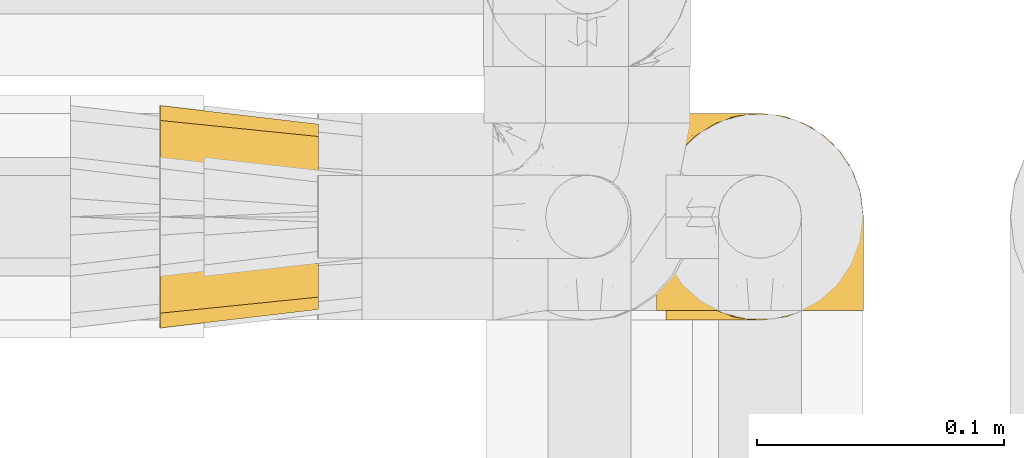
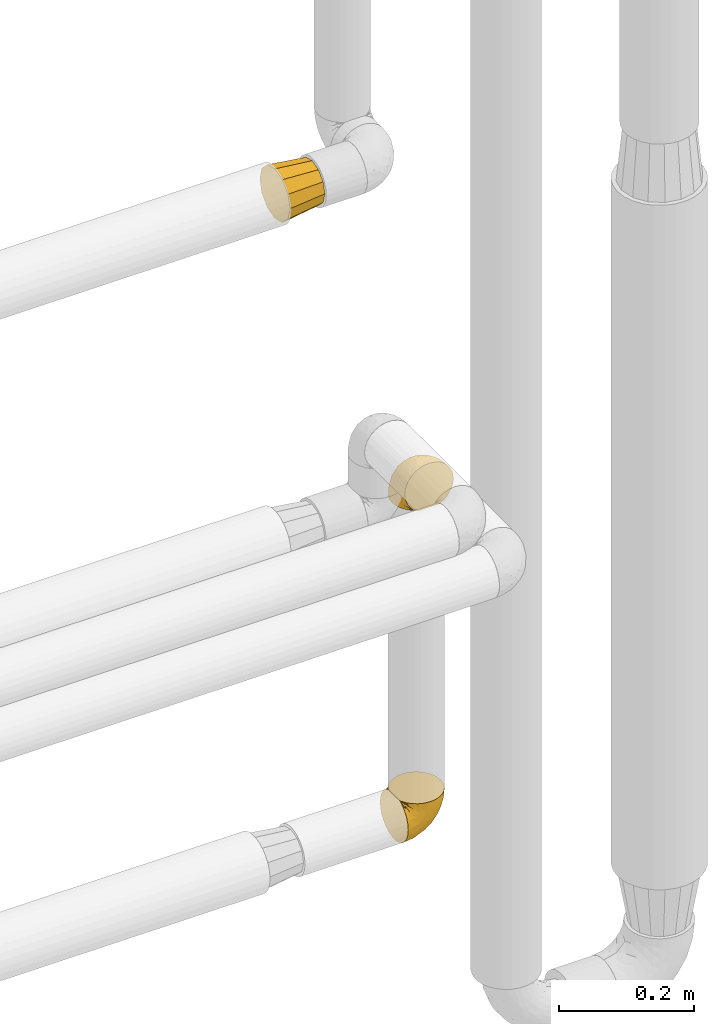
# One storey, part 457 of 827: 3 coverings.
"""IFC2X3 building model written with IfcOpenShell, lengths in millimetres."""

from ifc_helpers import new_model, entity, si_unit, converted_unit, derived_unit, direction, frame, origin, place, context, subcontext, project, spatial, faceted_brep, element, save


model = new_model("IFC2X3")

# Units and contexts
model_context = context("Model", 3, precision=0.01, world=origin(), true_north=direction((6.12303176911189e-17, 1.0)))
body_context = subcontext(model_context, "Body", "Model", "MODEL_VIEW")
ifc_project = project(units=[si_unit("LENGTHUNIT", "METRE", prefix="MILLI"), si_unit("AREAUNIT", "SQUARE_METRE"), si_unit("VOLUMEUNIT", "CUBIC_METRE"), converted_unit("PLANEANGLEUNIT", "DEGREE", entity("IfcRatioMeasure", 0.0174532925199433), si_unit("PLANEANGLEUNIT", "RADIAN"), dimensions=[0, 0, 0, 0, 0, 0, 0]), si_unit("MASSUNIT", "GRAM", prefix="KILO"), derived_unit("MASSDENSITYUNIT", [(si_unit("MASSUNIT", "GRAM", prefix="KILO"), 1), (si_unit("LENGTHUNIT", "METRE"), -3)]), derived_unit("MOMENTOFINERTIAUNIT", [(si_unit("LENGTHUNIT", "METRE"), 4)]), si_unit("TIMEUNIT", "SECOND"), si_unit("FREQUENCYUNIT", "HERTZ"), si_unit("THERMODYNAMICTEMPERATUREUNIT", "DEGREE_CELSIUS"), derived_unit("THERMALTRANSMITTANCEUNIT", [(si_unit("MASSUNIT", "GRAM", prefix="KILO"), 1), (si_unit("THERMODYNAMICTEMPERATUREUNIT", "KELVIN"), -1), (si_unit("TIMEUNIT", "SECOND"), -3)]), derived_unit("VOLUMETRICFLOWRATEUNIT", [(si_unit("LENGTHUNIT", "METRE"), 3), (si_unit("TIMEUNIT", "SECOND"), -1)]), derived_unit("MASSFLOWRATEUNIT", [(si_unit("MASSUNIT", "GRAM", prefix="KILO"), 1), (si_unit("TIMEUNIT", "SECOND"), -1)]), derived_unit("ROTATIONALFREQUENCYUNIT", [(si_unit("TIMEUNIT", "SECOND"), -1)]), si_unit("ELECTRICCURRENTUNIT", "AMPERE"), si_unit("ELECTRICVOLTAGEUNIT", "VOLT"), si_unit("POWERUNIT", "WATT"), si_unit("FORCEUNIT", "NEWTON", prefix="KILO"), si_unit("ILLUMINANCEUNIT", "LUX"), si_unit("LUMINOUSFLUXUNIT", "LUMEN"), si_unit("LUMINOUSINTENSITYUNIT", "CANDELA"), derived_unit("USERDEFINED", [(si_unit("MASSUNIT", "GRAM", prefix="KILO"), -1), (si_unit("LENGTHUNIT", "METRE"), -2), (si_unit("TIMEUNIT", "SECOND"), 3), (si_unit("LUMINOUSFLUXUNIT", "LUMEN"), 1)]), derived_unit("LINEARVELOCITYUNIT", [(si_unit("LENGTHUNIT", "METRE"), 1), (si_unit("TIMEUNIT", "SECOND"), -1)]), si_unit("PRESSUREUNIT", "PASCAL"), derived_unit("USERDEFINED", [(si_unit("LENGTHUNIT", "METRE"), -2), (si_unit("MASSUNIT", "GRAM", prefix="KILO"), 1), (si_unit("TIMEUNIT", "SECOND"), -2)]), derived_unit("LINEARFORCEUNIT", [(si_unit("MASSUNIT", "GRAM", prefix="KILO"), 1), (si_unit("LENGTHUNIT", "METRE"), 1), (si_unit("TIMEUNIT", "SECOND"), -2), (si_unit("LENGTHUNIT", "METRE"), -1)]), derived_unit("PLANARFORCEUNIT", [(si_unit("MASSUNIT", "GRAM", prefix="KILO"), 1), (si_unit("LENGTHUNIT", "METRE"), 1), (si_unit("TIMEUNIT", "SECOND"), -2), (si_unit("LENGTHUNIT", "METRE"), -2)])], contexts=[model_context])

# Site, building, storey
site_placement = place(None, origin())
site = spatial("IfcSite", under=ifc_project, at=site_placement, CompositionType="ELEMENT")
building_placement = place(site_placement, origin())
building = spatial("IfcBuilding", under=site, at=building_placement, CompositionType="ELEMENT")
storey_placement = place(building_placement, frame((0.0, 0.0, 28200.0)))
storey = spatial("IfcBuildingStorey", under=building, at=storey_placement, Name="08", CompositionType="ELEMENT", Elevation=28200.0)

# Coverings
covering_1_placement = place(storey_placement, frame((56390.69, 17453.4, 1945.9)))
element("IfcCovering", 1, at=covering_1_placement, inside=storey, Name=":ADSK_", ObjectType=":ADSK_", PredefinedType="INSULATION", context=body_context, shape_type="Brep", body=[
    faceted_brep([(64.0, 9.1, 46.6), (64.0, 11.61, 37.22), (64.0, 14.12, 27.85), (64.0, 20.98, 20.98), (64.0, 27.85, 14.12), (64.0, 37.22, 11.61), (64.0, 46.6, 9.1), (64.0, 55.97, 11.61), (64.0, 65.35, 14.12), (64.0, 72.21, 20.98), (64.0, 79.07, 27.85), (64.0, 81.58, 37.22), (64.0, 84.1, 46.6), (64.0, 81.58, 55.97), (64.0, 79.07, 65.35), (64.0, 72.21, 72.21), (64.0, 65.35, 79.07), (64.0, 55.97, 81.58), (64.0, 46.6, 84.1), (64.0, 37.22, 81.58), (64.0, 27.85, 79.07), (64.0, 20.98, 72.21), (64.0, 14.12, 65.35), (64.0, 11.61, 55.97), (0.0, 77.33, 77.33), (0.0, 85.57, 69.1), (0.0, 88.1, 59.65), (0.0, 91.6, 46.6), (0.0, 88.1, 33.54), (0.0, 85.57, 24.1), (0.0, 77.33, 15.86), (0.0, 69.1, 7.62), (0.0, 59.65, 5.09), (0.0, 46.6, 1.6), (0.0, 33.54, 5.09), (0.0, 24.1, 7.62), (0.0, 15.86, 15.86), (0.0, 7.62, 24.1), (0.0, 5.09, 33.54), (0.0, 1.6, 46.6), (0.0, 5.09, 59.65), (0.0, 7.62, 69.1), (0.0, 15.86, 77.33), (0.0, 24.1, 85.57), (0.0, 33.54, 88.1), (0.0, 46.6, 91.6), (0.0, 59.65, 88.1), (0.0, 69.1, 85.57)], [[[0, 1, 2, 3, 4, 5, 6, 7, 8, 9, 10, 11, 12, 13, 14, 15, 16, 17, 18, 19, 20, 21, 22, 23]], [[24, 25, 26, 27, 28, 29, 30, 31, 32, 33, 34, 35, 36, 37, 38, 39, 40, 41, 42, 43, 44, 45, 46, 47]], [[4, 35, 34, 33, 6, 5]], [[37, 36, 35, 4, 3, 2]], [[1, 0, 39, 38, 37, 2]], [[10, 29, 28, 27, 12, 11]], [[31, 30, 29, 10, 9, 8]], [[7, 6, 33, 32, 31, 8]], [[16, 47, 46, 45, 18, 17]], [[25, 24, 47, 16, 15, 14]], [[13, 12, 27, 26, 25, 14]], [[22, 41, 40, 39, 0, 23]], [[43, 42, 41, 22, 21, 20]], [[19, 18, 45, 44, 43, 20]]]),
])
covering_2_placement = place(storey_placement, frame((56589.78, 17460.4, 1360.4)))
element("IfcCovering", 2, at=covering_2_placement, inside=storey, Name=":ADSK_", ObjectType=":ADSK_", PredefinedType="INSULATION", context=body_context, shape_type="Brep", body=[
    faceted_brep([(5.74, 57.76, 1.6), (10.73, 65.69, 1.6), (17.36, 72.32, 1.6), (25.29, 77.3, 1.6), (34.14, 80.4, 1.6), (43.45, 81.45, 1.6), (52.76, 80.39, 1.6), (61.61, 77.3, 1.6), (69.54, 72.31, 1.6), (76.17, 65.68, 1.6), (81.15, 57.75, 1.6), (84.25, 48.9, 1.6), (85.3, 39.6, 1.6), (84.23, 30.22, 1.6), (81.1, 21.33, 1.6), (76.06, 13.37, 1.6), (69.36, 6.73, 1.6), (61.36, 1.77, 1.6), (60.44, 1.77, 1.6), (59.52, 1.77, 1.6), (58.72, 1.77, 1.6), (57.4, 1.77, 1.6), (56.08, 1.77, 1.6), (54.76, 1.77, 1.6), (53.44, 1.77, 1.6), (52.12, 1.77, 1.6), (50.8, 1.77, 1.6), (49.47, 1.77, 1.6), (48.15, 1.77, 1.6), (46.83, 1.77, 1.6), (45.51, 1.77, 1.6), (44.19, 1.77, 1.6), (42.87, 1.77, 1.6), (41.55, 1.77, 1.6), (40.23, 1.77, 1.6), (39.31, 1.77, 1.6), (38.39, 1.77, 1.6), (37.48, 1.77, 1.6), (36.56, 1.77, 1.6), (35.64, 1.77, 1.6), (34.72, 1.77, 1.6), (33.8, 1.77, 1.6), (32.88, 1.77, 1.6), (31.96, 1.77, 1.6), (31.05, 1.77, 1.6), (30.13, 1.77, 1.6), (29.21, 1.77, 1.6), (28.29, 1.77, 1.6), (27.37, 1.77, 1.6), (26.45, 1.77, 1.6), (25.53, 1.77, 1.6), (17.52, 6.74, 1.6), (10.82, 13.38, 1.6), (5.78, 21.35, 1.6), (2.65, 30.24, 1.6), (1.6, 39.6, 1.6), (2.65, 48.91, 1.6), (69.37, 1.6, 6.74), (76.06, 1.6, 13.37), (81.1, 1.6, 21.34), (84.23, 1.6, 30.23), (85.3, 1.6, 39.6), (83.87, 1.6, 50.43), (79.69, 1.6, 60.52), (73.04, 1.6, 69.19), (64.37, 1.6, 75.84), (54.28, 1.6, 80.02), (43.45, 1.6, 81.45), (32.61, 1.6, 80.02), (22.52, 1.6, 75.84), (13.85, 1.6, 69.19), (7.2, 1.6, 60.52), (3.02, 1.6, 50.43), (1.6, 1.6, 39.6), (2.66, 1.6, 30.23), (5.79, 1.6, 21.34), (10.83, 1.6, 13.37), (17.52, 1.6, 6.74), (25.53, 1.6, 1.77), (26.45, 1.6, 1.77), (27.77, 1.6, 1.77), (28.89, 1.6, 1.77), (30.01, 1.6, 1.77), (31.13, 1.6, 1.77), (32.25, 1.6, 1.77), (33.37, 1.6, 1.77), (34.49, 1.6, 1.77), (35.61, 1.6, 1.77), (36.73, 1.6, 1.77), (37.85, 1.6, 1.77), (38.97, 1.6, 1.77), (40.09, 1.6, 1.77), (41.21, 1.6, 1.77), (42.33, 1.6, 1.77), (43.45, 1.6, 1.77), (44.77, 1.6, 1.77), (46.09, 1.6, 1.77), (47.41, 1.6, 1.77), (48.73, 1.6, 1.77), (50.05, 1.6, 1.77), (51.37, 1.6, 1.77), (52.69, 1.6, 1.77), (54.01, 1.6, 1.77), (54.93, 1.6, 1.77), (55.85, 1.6, 1.77), (56.76, 1.6, 1.77), (57.68, 1.6, 1.77), (58.6, 1.6, 1.77), (59.52, 1.6, 1.77), (60.44, 1.6, 1.77), (61.36, 1.6, 1.77), (32.81, 1.71, 1.73), (31.73, 1.73, 1.72), (50.71, 1.71, 1.73), (51.76, 1.72, 1.72), (42.89, 1.71, 1.73), (41.81, 1.72, 1.73), (25.53, 1.72, 1.72), (26.91, 1.72, 1.72), (40.71, 1.72, 1.72), (60.15, 1.72, 1.72), (39.53, 1.72, 1.72), (57.22, 1.72, 1.73), (58.17, 1.7, 1.74), (47.12, 1.72, 1.72), (33.93, 1.73, 1.71), (35.05, 1.72, 1.73), (46.09, 1.73, 1.71), (45.02, 1.73, 1.72), (43.95, 1.72, 1.73), (59.12, 1.72, 1.72), (38.49, 1.71, 1.73), (49.68, 1.72, 1.72), (53.35, 1.71, 1.73), (54.4, 1.72, 1.72), (56.2, 1.72, 1.72), (36.2, 1.72, 1.72), (37.29, 1.73, 1.71), (30.57, 1.72, 1.72), (29.45, 1.71, 1.73), (28.01, 1.73, 1.71), (61.36, 1.72, 1.72), (25.53, 1.74, 1.68), (25.53, 1.75, 1.64), (61.36, 1.75, 1.64), (61.36, 1.74, 1.68), (25.53, 1.64, 1.75), (25.53, 1.68, 1.74), (61.36, 1.68, 1.74), (61.36, 1.64, 1.75), (55.3, 1.74, 1.7), (48.18, 1.71, 1.73), (82.92, 8.98, 24.54), (85.3, 37.05, 11.1), (82.92, 24.69, 8.47), (78.8, 15.28, 9.11), (78.8, 16.86, 4.86), (70.46, 6.58, 5.0), (71.16, 5.71, 6.81), (85.3, 11.1, 37.05), (76.1, 10.79, 9.03), (72.9, 4.13, 9.47), (78.81, 6.62, 16.39), (72.89, 9.52, 3.95), (74.06, 6.14, 9.9), (83.71, 17.79, 22.7), (85.3, 20.6, 34.5), (85.3, 8.73, 37.68), (83.61, 23.66, 15.82), (85.3, 34.5, 20.6), (80.61, 15.32, 14.37), (85.3, 27.55, 27.55), (67.83, 3.31, 5.2), (78.81, 9.81, 14.88), (85.3, 37.68, 8.73), (54.78, 67.23, 44.27), (57.27, 76.64, 20.94), (43.45, 75.37, 32.15), (84.45, 14.58, 46.13), (84.39, 23.71, 42.67), (77.16, 34.34, 55.18), (68.92, 29.1, 67.27), (76.65, 18.02, 62.91), (82.11, 22.27, 51.5), (82.11, 10.97, 54.79), (78.88, 56.79, 25.78), (78.88, 60.76, 13.05), (73.04, 67.04, 18.46), (84.47, 36.11, 32.4), (65.72, 68.85, 31.07), (51.16, 24.58, 77.32), (59.46, 21.54, 75.62), (43.45, 78.4, 16.9), (68.92, 14.11, 71.69), (51.18, 53.42, 61.4), (57.42, 58.19, 54.47), (83.48, 44.49, 27.66), (82.95, 51.77, 14.53), (65.72, 73.69, 15.56), (78.97, 45.89, 42.26), (82.64, 35.97, 41.51), (75.14, 56.55, 36.93), (68.58, 60.03, 42.72), (61.95, 63.64, 44.68), (58.11, 34.98, 71.2), (51.07, 40.58, 70.48), (43.45, 32.15, 75.37), (58.51, 47.26, 63.65), (43.45, 58.06, 58.06), (43.45, 66.71, 45.11), (43.45, 16.9, 78.4), (65.68, 52.08, 54.95), (70.41, 41.21, 59.31), (73.04, 49.76, 49.01), (43.45, 45.11, 66.71), (4.78, 15.65, 53.75), (35.48, 24.57, 77.27), (29.45, 50.54, 61.6), (32.11, 67.25, 44.24), (13.86, 67.06, 18.46), (21.19, 73.7, 15.55), (10.24, 26.13, 60.14), (17.97, 19.54, 70.5), (18.88, 38.96, 63.0), (8.01, 56.8, 25.78), (8.01, 60.77, 13.05), (3.95, 51.78, 14.53), (22.45, 59.09, 48.5), (2.4, 19.25, 44.23), (1.6, 20.6, 34.5), (1.6, 11.1, 37.05), (1.6, 37.68, 8.73), (29.05, 15.21, 77.68), (10.24, 12.76, 64.08), (35.7, 40.93, 70.25), (29.63, 76.65, 20.93), (8.75, 39.5, 49.9), (4.54, 25.01, 49.6), (21.19, 68.86, 31.06), (2.28, 26.7, 39.62), (2.53, 34.95, 34.42), (1.6, 34.5, 20.6), (1.6, 27.55, 27.55), (13.86, 61.27, 33.36), (3.41, 44.5, 27.68), (1.6, 37.05, 11.1), (2.35, 10.25, 46.67), (13.86, 49.78, 49.0), (7.35, 47.51, 38.94), (27.43, 29.38, 73.05), (13.39, 40.01, 56.63), (4.32, 33.36, 43.85), (3.97, 8.98, 24.54), (3.27, 23.67, 15.82), (3.97, 24.71, 8.47), (8.08, 15.29, 9.12), (13.99, 4.13, 9.47), (12.83, 6.14, 9.91), (8.08, 4.96, 16.85), (8.08, 9.81, 14.88), (19.06, 3.31, 5.2), (15.74, 5.7, 6.81), (13.98, 9.53, 3.96), (16.42, 6.59, 5.0), (8.08, 16.63, 5.86), (6.27, 15.34, 14.38), (10.78, 10.8, 9.04), (3.18, 17.79, 22.7)], [[[0, 1, 2, 3, 4, 5, 6, 7, 8, 9, 10, 11, 12, 13, 14, 15, 16, 17, 18, 19, 20, 21, 22, 23, 24, 25, 26, 27, 28, 29, 30, 31, 32, 33, 34, 35, 36, 37, 38, 39, 40, 41, 42, 43, 44, 45, 46, 47, 48, 49, 50, 51, 52, 53, 54, 55, 56]], [[57, 58, 59, 60, 61, 62, 63, 64, 65, 66, 67, 68, 69, 70, 71, 72, 73, 74, 75, 76, 77, 78, 79, 80, 81, 82, 83, 84, 85, 86, 87, 88, 89, 90, 91, 92, 93, 94, 95, 96, 97, 98, 99, 100, 101, 102, 103, 104, 105, 106, 107, 108, 109, 110]], [[111, 84, 112]], [[113, 26, 114]], [[114, 101, 100]], [[115, 93, 116]], [[79, 117, 118]], [[33, 116, 119]], [[117, 49, 118]], [[19, 18, 120]], [[119, 121, 34]], [[122, 21, 123]], [[97, 96, 124]], [[86, 125, 126]], [[116, 92, 119]], [[127, 96, 128]], [[32, 129, 115]], [[19, 120, 130]], [[121, 90, 131]], [[94, 115, 129]], [[115, 116, 32]], [[118, 49, 48]], [[113, 99, 132]], [[133, 114, 25]], [[24, 134, 133]], [[135, 22, 122]], [[136, 137, 88]], [[84, 83, 112]], [[138, 82, 139]], [[130, 20, 19]], [[118, 48, 140]], [[81, 140, 139]], [[123, 21, 20]], [[141, 120, 18]], [[139, 82, 81]], [[130, 107, 123]], [[49, 117, 142, 143, 50]], [[18, 17, 144, 145, 141]], [[79, 78, 146, 147, 117]], [[109, 141, 148, 149, 110]], [[102, 133, 134]], [[105, 135, 122]], [[118, 80, 79]], [[80, 118, 140]], [[120, 109, 108]], [[47, 46, 140, 48]], [[81, 80, 140]], [[44, 112, 138]], [[93, 115, 94]], [[46, 139, 140]], [[46, 45, 139]], [[139, 45, 138]], [[138, 112, 83]], [[85, 84, 111]], [[112, 43, 111]], [[83, 82, 138]], [[106, 122, 123]], [[105, 122, 106]], [[21, 122, 22]], [[124, 29, 28]], [[33, 32, 116]], [[128, 129, 31]], [[32, 31, 129]], [[34, 33, 119]], [[116, 93, 92]], [[129, 95, 94]], [[95, 129, 128]], [[41, 40, 125, 42]], [[119, 91, 121]], [[36, 35, 131, 37]], [[137, 131, 89]], [[121, 131, 35]], [[90, 121, 91]], [[119, 92, 91]], [[136, 126, 39]], [[125, 86, 85]], [[42, 125, 111]], [[85, 111, 125]], [[150, 23, 22]], [[130, 108, 107]], [[130, 123, 20]], [[107, 106, 123]], [[137, 37, 131]], [[136, 38, 137]], [[89, 88, 137]], [[131, 90, 89]], [[124, 151, 97]], [[40, 39, 126]], [[87, 126, 136]], [[86, 126, 87]], [[136, 88, 87]], [[40, 126, 125]], [[39, 38, 136]], [[95, 128, 96]], [[30, 128, 31]], [[29, 124, 127]], [[127, 128, 30]], [[151, 124, 28]], [[127, 30, 29]], [[127, 124, 96]], [[151, 98, 97]], [[45, 44, 138]], [[26, 113, 132]], [[113, 100, 99]], [[132, 151, 27]], [[27, 26, 132]], [[26, 25, 114]], [[100, 113, 114]], [[101, 133, 102]], [[133, 101, 114]], [[28, 27, 151]], [[132, 99, 98]], [[23, 134, 24]], [[25, 24, 133]], [[134, 23, 150]], [[135, 104, 150]], [[150, 104, 103]], [[103, 102, 134]], [[130, 120, 108]], [[109, 120, 141]], [[42, 111, 43]], [[112, 44, 43]], [[104, 135, 105]], [[134, 150, 103]], [[135, 150, 22]], [[35, 34, 121]], [[137, 38, 37]], [[98, 151, 132]], [[59, 152, 60]], [[13, 153, 154]], [[155, 156, 154]], [[157, 158, 141]], [[159, 60, 152]], [[160, 157, 155]], [[161, 162, 58]], [[58, 162, 59]], [[144, 16, 163]], [[58, 57, 161]], [[162, 161, 164]], [[157, 163, 155]], [[163, 16, 15]], [[57, 149, 161]], [[152, 165, 166]], [[157, 144, 163]], [[60, 159, 167, 61]], [[156, 14, 154]], [[163, 156, 155]], [[155, 154, 168]], [[168, 154, 169]], [[155, 170, 160]], [[57, 110, 149]], [[144, 17, 16]], [[156, 15, 14]], [[171, 165, 168]], [[158, 164, 172]], [[14, 13, 154]], [[157, 141, 145, 144]], [[173, 164, 158]], [[173, 160, 170]], [[171, 166, 165]], [[168, 165, 170]], [[168, 169, 171]], [[152, 173, 165]], [[170, 155, 168]], [[165, 173, 170]], [[160, 173, 158]], [[172, 149, 148]], [[148, 141, 158]], [[158, 157, 160]], [[152, 166, 159]], [[173, 152, 162]], [[59, 162, 152]], [[13, 12, 174, 153]], [[153, 169, 154]], [[15, 156, 163]], [[162, 164, 173]], [[172, 164, 161]], [[149, 172, 161]], [[158, 172, 148]], [[175, 176, 177]], [[178, 166, 179]], [[180, 181, 182]], [[183, 184, 178]], [[185, 186, 187]], [[171, 188, 179]], [[174, 12, 11]], [[189, 176, 175]], [[190, 66, 191]], [[176, 6, 192]], [[193, 65, 64]], [[63, 184, 182]], [[63, 182, 64]], [[65, 193, 191]], [[184, 63, 62]], [[175, 194, 195]], [[196, 169, 197]], [[174, 11, 197]], [[8, 7, 198]], [[187, 9, 8]], [[197, 169, 153, 174]], [[197, 11, 10]], [[186, 197, 10]], [[199, 180, 200]], [[197, 185, 196]], [[201, 189, 202]], [[201, 187, 189]], [[195, 203, 175]], [[191, 204, 190]], [[176, 7, 6]], [[177, 176, 192]], [[189, 198, 176]], [[65, 191, 66]], [[198, 187, 8]], [[205, 206, 190]], [[9, 186, 10]], [[181, 207, 204]], [[208, 175, 177, 209]], [[66, 190, 210]], [[211, 212, 213]], [[190, 204, 205]], [[180, 182, 183]], [[193, 182, 181]], [[62, 61, 167]], [[196, 185, 199]], [[196, 200, 188]], [[6, 5, 192]], [[176, 198, 7]], [[187, 198, 189]], [[187, 186, 9]], [[197, 186, 185]], [[200, 180, 183]], [[180, 213, 212]], [[179, 183, 178]], [[185, 201, 199]], [[210, 190, 206]], [[210, 67, 66]], [[205, 204, 207]], [[194, 205, 207]], [[194, 214, 205]], [[195, 194, 207]], [[208, 194, 175]], [[207, 211, 195]], [[202, 203, 211]], [[212, 207, 181]], [[202, 211, 213]], [[201, 202, 213]], [[189, 175, 203]], [[199, 201, 213]], [[187, 201, 185]], [[180, 199, 213]], [[196, 199, 200]], [[211, 203, 195]], [[189, 203, 202]], [[207, 212, 211]], [[180, 212, 181]], [[214, 194, 208]], [[214, 206, 205]], [[196, 188, 169]], [[181, 204, 191]], [[182, 193, 64]], [[191, 193, 181]], [[178, 62, 167]], [[182, 184, 183]], [[62, 178, 184]], [[178, 167, 159, 166]], [[171, 179, 166]], [[200, 183, 179]], [[179, 188, 200]], [[169, 188, 171]], [[71, 215, 72]], [[206, 216, 210]], [[217, 208, 218]], [[216, 68, 210]], [[219, 220, 2]], [[221, 222, 223]], [[224, 225, 226]], [[227, 223, 217]], [[228, 229, 230]], [[56, 231, 226]], [[232, 222, 69]], [[56, 55, 231]], [[70, 233, 71]], [[71, 233, 215]], [[0, 56, 226]], [[208, 217, 234]], [[218, 177, 235]], [[221, 236, 237]], [[238, 220, 219]], [[1, 219, 2]], [[68, 216, 232]], [[235, 3, 220]], [[235, 192, 4]], [[1, 0, 225]], [[228, 239, 229]], [[240, 241, 242]], [[243, 238, 219]], [[224, 226, 244]], [[226, 241, 244]], [[3, 235, 4]], [[69, 222, 70]], [[225, 219, 1]], [[218, 235, 238]], [[243, 219, 224]], [[218, 227, 217]], [[3, 2, 220]], [[218, 208, 209, 177]], [[226, 231, 245, 241]], [[215, 228, 246]], [[247, 248, 236]], [[248, 224, 244]], [[223, 222, 249]], [[233, 222, 221]], [[242, 239, 240]], [[248, 247, 243]], [[217, 223, 249]], [[250, 247, 236]], [[216, 234, 249]], [[218, 238, 227]], [[192, 235, 177]], [[192, 5, 4]], [[72, 246, 73]], [[235, 220, 238]], [[226, 225, 0]], [[219, 225, 224]], [[240, 248, 244]], [[239, 242, 229]], [[236, 248, 251]], [[68, 67, 210]], [[234, 216, 206]], [[216, 249, 232]], [[234, 206, 214, 208]], [[249, 234, 217]], [[222, 232, 249]], [[69, 68, 232]], [[246, 228, 230]], [[237, 228, 215]], [[243, 227, 238]], [[223, 227, 247]], [[73, 246, 230]], [[215, 246, 72]], [[248, 243, 224]], [[227, 243, 247]], [[237, 236, 251]], [[250, 221, 223]], [[222, 233, 70]], [[215, 233, 221]], [[221, 237, 215]], [[239, 237, 251]], [[237, 239, 228]], [[239, 251, 240]], [[248, 240, 251]], [[241, 240, 244]], [[221, 250, 236]], [[223, 247, 250]], [[74, 230, 252]], [[253, 254, 255]], [[146, 77, 256]], [[257, 258, 259]], [[260, 256, 257]], [[260, 261, 147]], [[75, 74, 252]], [[51, 143, 262]], [[263, 143, 142, 117]], [[256, 77, 76]], [[252, 258, 75]], [[253, 241, 254]], [[254, 245, 54]], [[258, 256, 76]], [[53, 52, 264]], [[255, 265, 253]], [[254, 264, 255]], [[255, 264, 262]], [[75, 258, 76]], [[265, 255, 266]], [[255, 262, 263]], [[51, 50, 143]], [[54, 245, 231, 55]], [[51, 262, 52]], [[253, 267, 242]], [[254, 54, 53]], [[266, 259, 265]], [[146, 78, 77]], [[263, 117, 261]], [[146, 256, 260]], [[257, 259, 261]], [[267, 253, 265]], [[229, 267, 252]], [[242, 267, 229]], [[242, 241, 253]], [[252, 267, 259]], [[255, 263, 266]], [[259, 267, 265]], [[261, 117, 147]], [[263, 261, 266]], [[259, 266, 261]], [[230, 74, 73]], [[230, 229, 252]], [[259, 258, 252]], [[254, 241, 245]], [[53, 264, 254]], [[52, 262, 264]], [[143, 263, 262]], [[258, 257, 256]], [[261, 260, 257]], [[146, 260, 147]]]),
])
covering_3_placement = place(storey_placement, frame((56593.63, 17456.55, 749.05)))
element("IfcCovering", 3, at=covering_3_placement, inside=storey, Name=":ADSK_", ObjectType=":ADSK_", PredefinedType="INSULATION", context=body_context, shape_type="Brep", body=[
    faceted_brep([(1.6, 81.15, 25.28), (1.6, 76.16, 17.35), (1.6, 69.53, 10.72), (1.6, 61.6, 5.74), (1.6, 52.75, 2.64), (1.6, 43.45, 1.6), (1.6, 34.13, 2.65), (1.6, 25.28, 5.74), (1.6, 17.35, 10.73), (1.6, 10.72, 17.36), (1.6, 5.74, 25.29), (1.6, 2.64, 34.14), (1.6, 1.6, 43.45), (1.6, 2.66, 52.82), (1.6, 5.79, 61.71), (1.6, 10.83, 69.67), (1.6, 17.53, 76.31), (1.6, 25.53, 81.27), (1.6, 26.45, 81.27), (1.6, 27.37, 81.27), (1.6, 28.17, 81.27), (1.6, 29.49, 81.27), (1.6, 30.81, 81.27), (1.6, 32.13, 81.27), (1.6, 33.45, 81.27), (1.6, 34.78, 81.27), (1.6, 36.1, 81.27), (1.6, 37.42, 81.27), (1.6, 38.74, 81.27), (1.6, 40.06, 81.27), (1.6, 41.38, 81.27), (1.6, 42.7, 81.27), (1.6, 44.02, 81.27), (1.6, 45.34, 81.27), (1.6, 46.66, 81.27), (1.6, 47.58, 81.27), (1.6, 48.5, 81.27), (1.6, 49.41, 81.27), (1.6, 50.33, 81.27), (1.6, 51.25, 81.27), (1.6, 52.17, 81.27), (1.6, 53.09, 81.27), (1.6, 54.01, 81.27), (1.6, 54.93, 81.27), (1.6, 55.85, 81.27), (1.6, 56.76, 81.27), (1.6, 57.68, 81.27), (1.6, 58.6, 81.27), (1.6, 59.52, 81.27), (1.6, 60.44, 81.27), (1.6, 61.36, 81.27), (1.6, 69.37, 76.3), (1.6, 76.07, 69.66), (1.6, 81.11, 61.69), (1.6, 84.24, 52.8), (1.6, 85.3, 43.45), (1.6, 84.24, 34.13), (6.74, 17.52, 81.45), (13.37, 10.83, 81.45), (21.34, 5.79, 81.45), (30.23, 2.66, 81.45), (39.6, 1.6, 81.45), (50.43, 3.02, 81.45), (60.52, 7.2, 81.45), (69.19, 13.85, 81.45), (75.84, 22.52, 81.45), (80.02, 32.61, 81.45), (81.45, 43.45, 81.45), (80.02, 54.28, 81.45), (75.84, 64.37, 81.45), (69.19, 73.04, 81.45), (60.52, 79.69, 81.45), (50.43, 83.87, 81.45), (39.6, 85.3, 81.45), (30.23, 84.23, 81.45), (21.34, 81.1, 81.45), (13.37, 76.06, 81.45), (6.74, 69.37, 81.45), (1.77, 61.36, 81.45), (1.77, 60.44, 81.45), (1.77, 59.12, 81.45), (1.77, 58.0, 81.45), (1.77, 56.88, 81.45), (1.77, 55.76, 81.45), (1.77, 54.64, 81.45), (1.77, 53.52, 81.45), (1.77, 52.4, 81.45), (1.77, 51.28, 81.45), (1.77, 50.16, 81.45), (1.77, 49.04, 81.45), (1.77, 47.92, 81.45), (1.77, 46.8, 81.45), (1.77, 45.68, 81.45), (1.77, 44.56, 81.45), (1.77, 43.45, 81.45), (1.77, 42.12, 81.45), (1.77, 40.8, 81.45), (1.77, 39.48, 81.45), (1.77, 38.16, 81.45), (1.77, 36.84, 81.45), (1.77, 35.52, 81.45), (1.77, 34.2, 81.45), (1.77, 32.88, 81.45), (1.77, 31.96, 81.45), (1.77, 31.05, 81.45), (1.77, 30.13, 81.45), (1.77, 29.21, 81.45), (1.77, 28.29, 81.45), (1.77, 27.37, 81.45), (1.77, 26.45, 81.45), (1.77, 25.53, 81.45), (1.73, 54.08, 81.33), (1.72, 55.16, 81.32), (1.73, 36.18, 81.33), (1.72, 35.13, 81.32), (1.73, 44.01, 81.33), (1.73, 45.08, 81.32), (1.72, 61.36, 81.32), (1.72, 59.98, 81.32), (1.72, 46.18, 81.32), (1.72, 26.74, 81.32), (1.72, 47.36, 81.32), (1.73, 29.67, 81.32), (1.74, 28.72, 81.34), (1.72, 39.77, 81.32), (1.71, 52.96, 81.31), (1.73, 51.84, 81.33), (1.71, 40.8, 81.31), (1.72, 41.87, 81.32), (1.73, 42.94, 81.33), (1.72, 27.77, 81.32), (1.73, 48.4, 81.33), (1.72, 37.21, 81.32), (1.73, 33.54, 81.33), (1.72, 32.49, 81.32), (1.72, 30.69, 81.32), (1.72, 50.69, 81.32), (1.71, 49.6, 81.31), (1.72, 56.32, 81.32), (1.73, 57.44, 81.33), (1.71, 58.88, 81.31), (1.72, 25.53, 81.32), (1.68, 61.36, 81.3), (1.64, 25.53, 81.29), (1.68, 25.53, 81.3), (1.75, 61.36, 81.4), (1.74, 61.36, 81.36), (1.74, 25.53, 81.36), (1.75, 25.53, 81.4), (1.64, 61.36, 81.29), (1.7, 31.59, 81.3), (1.73, 38.71, 81.33), (24.54, 3.97, 74.06), (11.1, 1.6, 45.99), (8.47, 3.97, 58.35), (9.11, 8.09, 67.76), (4.86, 8.09, 66.18), (5.0, 16.43, 76.46), (6.81, 15.73, 77.33), (37.05, 1.6, 71.95), (9.03, 10.79, 72.25), (9.47, 13.99, 78.91), (16.39, 8.08, 76.42), (3.95, 14.0, 73.52), (9.9, 12.83, 76.9), (22.7, 3.18, 65.25), (34.5, 1.6, 62.45), (37.68, 1.6, 74.31), (15.82, 3.28, 59.38), (20.6, 1.6, 48.54), (14.37, 6.28, 67.72), (27.55, 1.6, 55.49), (5.2, 19.06, 79.73), (14.88, 8.08, 73.23), (8.73, 1.6, 45.36), (44.27, 32.11, 15.81), (20.94, 29.62, 6.4), (32.15, 43.45, 7.67), (46.13, 2.45, 68.46), (42.67, 2.5, 59.33), (55.18, 9.73, 48.7), (67.27, 17.97, 53.94), (62.91, 10.24, 65.02), (51.5, 4.78, 60.77), (54.79, 4.78, 72.07), (25.78, 8.01, 26.25), (13.05, 8.01, 22.29), (18.46, 13.85, 16.0), (32.4, 2.42, 46.93), (31.07, 21.17, 14.19), (77.32, 35.73, 58.46), (75.62, 27.43, 61.51), (16.9, 43.45, 4.64), (71.69, 17.97, 68.93), (61.4, 35.71, 29.62), (54.47, 29.47, 24.85), (27.66, 3.41, 38.55), (14.53, 3.94, 31.27), (15.56, 21.17, 9.35), (42.26, 7.92, 37.15), (41.51, 4.25, 47.07), (36.93, 11.75, 26.49), (42.72, 18.31, 23.01), (44.68, 24.94, 19.4), (71.2, 28.78, 48.06), (70.48, 35.82, 42.46), (75.37, 43.45, 50.89), (63.65, 28.38, 35.78), (58.06, 43.45, 24.98), (45.11, 43.45, 16.33), (78.4, 43.45, 66.14), (54.95, 21.21, 30.96), (59.31, 16.48, 41.83), (49.01, 13.85, 33.28), (66.71, 43.45, 37.94), (53.75, 82.11, 67.39), (77.27, 51.41, 58.47), (61.6, 57.45, 32.5), (44.24, 54.78, 15.79), (18.46, 73.03, 15.99), (15.55, 65.7, 9.34), (60.14, 76.65, 56.91), (70.5, 68.92, 63.5), (63.0, 68.01, 44.08), (25.78, 78.88, 26.24), (13.05, 78.88, 22.27), (14.53, 82.94, 31.26), (48.5, 64.44, 23.95), (44.23, 84.49, 63.79), (34.5, 85.3, 62.45), (37.05, 85.3, 71.95), (8.73, 85.3, 45.36), (77.68, 57.84, 67.83), (64.08, 76.65, 70.28), (70.25, 51.19, 42.11), (20.93, 57.26, 6.39), (49.9, 78.14, 43.54), (49.6, 82.35, 58.03), (31.06, 65.7, 14.18), (39.62, 84.61, 56.34), (34.42, 84.36, 48.09), (20.6, 85.3, 48.54), (27.55, 85.3, 55.49), (33.36, 73.03, 21.78), (27.68, 83.48, 38.54), (11.1, 85.3, 45.99), (46.67, 84.54, 72.79), (49.0, 73.03, 33.26), (38.94, 79.54, 35.53), (73.05, 59.46, 53.66), (56.63, 73.5, 43.03), (43.85, 82.57, 49.68), (24.54, 82.92, 74.06), (15.82, 83.62, 59.37), (8.47, 82.92, 58.34), (9.12, 78.81, 67.75), (9.47, 72.9, 78.91), (9.91, 74.06, 76.9), (16.85, 78.81, 78.08), (14.88, 78.81, 73.23), (5.2, 67.83, 79.73), (6.81, 71.15, 77.34), (3.96, 72.91, 73.51), (5.0, 70.47, 76.45), (5.86, 78.81, 66.41), (14.38, 80.62, 67.7), (9.04, 76.11, 72.24), (22.7, 83.71, 65.25)], [[[0, 1, 2, 3, 4, 5, 6, 7, 8, 9, 10, 11, 12, 13, 14, 15, 16, 17, 18, 19, 20, 21, 22, 23, 24, 25, 26, 27, 28, 29, 30, 31, 32, 33, 34, 35, 36, 37, 38, 39, 40, 41, 42, 43, 44, 45, 46, 47, 48, 49, 50, 51, 52, 53, 54, 55, 56]], [[57, 58, 59, 60, 61, 62, 63, 64, 65, 66, 67, 68, 69, 70, 71, 72, 73, 74, 75, 76, 77, 78, 79, 80, 81, 82, 83, 84, 85, 86, 87, 88, 89, 90, 91, 92, 93, 94, 95, 96, 97, 98, 99, 100, 101, 102, 103, 104, 105, 106, 107, 108, 109, 110]], [[111, 84, 112]], [[113, 26, 114]], [[114, 101, 100]], [[115, 93, 116]], [[79, 117, 118]], [[33, 116, 119]], [[117, 49, 118]], [[19, 18, 120]], [[119, 121, 34]], [[122, 21, 123]], [[97, 96, 124]], [[86, 125, 126]], [[116, 92, 119]], [[127, 96, 128]], [[32, 129, 115]], [[19, 120, 130]], [[121, 90, 131]], [[94, 115, 129]], [[115, 116, 32]], [[118, 49, 48]], [[113, 99, 132]], [[133, 114, 25]], [[24, 134, 133]], [[135, 22, 122]], [[136, 137, 88]], [[84, 83, 112]], [[138, 82, 139]], [[130, 20, 19]], [[118, 48, 140]], [[81, 140, 139]], [[123, 21, 20]], [[141, 120, 18]], [[139, 82, 81]], [[130, 107, 123]], [[49, 117, 142]], [[18, 143, 144]], [[79, 78, 145, 146, 117]], [[109, 141, 147, 148, 110]], [[102, 133, 134]], [[105, 135, 122]], [[118, 80, 79]], [[80, 118, 140]], [[18, 17, 143]], [[49, 142, 149, 50]], [[120, 109, 108]], [[47, 46, 140, 48]], [[81, 80, 140]], [[44, 112, 138]], [[93, 115, 94]], [[46, 139, 140]], [[46, 45, 139]], [[139, 45, 138]], [[138, 112, 83]], [[85, 84, 111]], [[112, 43, 111]], [[83, 82, 138]], [[106, 122, 123]], [[105, 122, 106]], [[21, 122, 22]], [[124, 29, 28]], [[33, 32, 116]], [[128, 129, 31]], [[32, 31, 129]], [[34, 33, 119]], [[116, 93, 92]], [[129, 95, 94]], [[95, 129, 128]], [[41, 40, 125, 42]], [[119, 91, 121]], [[36, 35, 131, 37]], [[137, 131, 89]], [[121, 131, 35]], [[90, 121, 91]], [[119, 92, 91]], [[136, 126, 39]], [[125, 86, 85]], [[42, 125, 111]], [[85, 111, 125]], [[150, 23, 22]], [[130, 108, 107]], [[130, 123, 20]], [[107, 106, 123]], [[137, 37, 131]], [[136, 38, 137]], [[89, 88, 137]], [[131, 90, 89]], [[124, 151, 97]], [[40, 39, 126]], [[87, 126, 136]], [[86, 126, 87]], [[136, 88, 87]], [[40, 126, 125]], [[39, 38, 136]], [[95, 128, 96]], [[30, 128, 31]], [[29, 124, 127]], [[127, 128, 30]], [[151, 124, 28]], [[127, 30, 29]], [[127, 124, 96]], [[151, 98, 97]], [[45, 44, 138]], [[26, 113, 132]], [[113, 100, 99]], [[132, 151, 27]], [[27, 26, 132]], [[26, 25, 114]], [[100, 113, 114]], [[101, 133, 102]], [[133, 101, 114]], [[28, 27, 151]], [[132, 99, 98]], [[23, 134, 24]], [[25, 24, 133]], [[134, 23, 150]], [[135, 104, 150]], [[150, 104, 103]], [[103, 102, 134]], [[130, 120, 108]], [[109, 120, 141]], [[42, 111, 43]], [[112, 44, 43]], [[104, 135, 105]], [[134, 150, 103]], [[135, 150, 22]], [[35, 34, 121]], [[137, 38, 37]], [[98, 151, 132]], [[59, 152, 60]], [[13, 153, 154]], [[155, 156, 154]], [[157, 158, 141]], [[159, 60, 152]], [[160, 157, 155]], [[161, 162, 58]], [[58, 162, 59]], [[143, 16, 163]], [[58, 57, 161]], [[162, 161, 164]], [[157, 163, 155]], [[163, 16, 15]], [[57, 148, 161]], [[152, 165, 166]], [[157, 143, 163]], [[60, 159, 167, 61]], [[156, 14, 154]], [[163, 156, 155]], [[155, 154, 168]], [[168, 154, 169]], [[155, 170, 160]], [[57, 110, 148]], [[143, 17, 16]], [[156, 15, 14]], [[171, 165, 168]], [[158, 164, 172]], [[14, 13, 154]], [[157, 141, 144, 143]], [[173, 164, 158]], [[173, 160, 170]], [[171, 166, 165]], [[168, 165, 170]], [[168, 169, 171]], [[152, 173, 165]], [[170, 155, 168]], [[165, 173, 170]], [[160, 173, 158]], [[172, 148, 147]], [[147, 141, 158]], [[158, 157, 160]], [[152, 166, 159]], [[173, 152, 162]], [[59, 162, 152]], [[13, 12, 174, 153]], [[153, 169, 154]], [[15, 156, 163]], [[162, 164, 173]], [[172, 164, 161]], [[148, 172, 161]], [[158, 172, 147]], [[175, 176, 177]], [[178, 166, 179]], [[180, 181, 182]], [[183, 184, 178]], [[185, 186, 187]], [[171, 188, 179]], [[174, 12, 11]], [[189, 176, 175]], [[190, 66, 191]], [[176, 6, 192]], [[193, 65, 64]], [[63, 184, 182]], [[63, 182, 64]], [[65, 193, 191]], [[184, 63, 62]], [[175, 194, 195]], [[196, 169, 197]], [[174, 11, 197]], [[8, 7, 198]], [[187, 9, 8]], [[197, 169, 153, 174]], [[197, 11, 10]], [[186, 197, 10]], [[199, 180, 200]], [[197, 185, 196]], [[201, 189, 202]], [[201, 187, 189]], [[195, 203, 175]], [[191, 204, 190]], [[176, 7, 6]], [[177, 176, 192]], [[189, 198, 176]], [[65, 191, 66]], [[198, 187, 8]], [[205, 206, 190]], [[9, 186, 10]], [[181, 207, 204]], [[208, 175, 177, 209]], [[66, 190, 210]], [[211, 212, 213]], [[190, 204, 205]], [[180, 182, 183]], [[193, 182, 181]], [[62, 61, 167]], [[196, 185, 199]], [[196, 200, 188]], [[6, 5, 192]], [[176, 198, 7]], [[187, 198, 189]], [[187, 186, 9]], [[197, 186, 185]], [[200, 180, 183]], [[180, 213, 212]], [[179, 183, 178]], [[185, 201, 199]], [[210, 190, 206]], [[210, 67, 66]], [[205, 204, 207]], [[194, 205, 207]], [[194, 214, 205]], [[195, 194, 207]], [[208, 194, 175]], [[207, 211, 195]], [[202, 203, 211]], [[212, 207, 181]], [[202, 211, 213]], [[201, 202, 213]], [[189, 175, 203]], [[199, 201, 213]], [[187, 201, 185]], [[180, 199, 213]], [[196, 199, 200]], [[211, 203, 195]], [[189, 203, 202]], [[207, 212, 211]], [[180, 212, 181]], [[214, 194, 208]], [[214, 206, 205]], [[196, 188, 169]], [[181, 204, 191]], [[182, 193, 64]], [[191, 193, 181]], [[178, 62, 167]], [[182, 184, 183]], [[62, 178, 184]], [[178, 167, 159, 166]], [[171, 179, 166]], [[200, 183, 179]], [[179, 188, 200]], [[169, 188, 171]], [[71, 215, 72]], [[206, 216, 210]], [[217, 208, 218]], [[216, 68, 210]], [[219, 220, 2]], [[221, 222, 223]], [[224, 225, 226]], [[227, 223, 217]], [[228, 229, 230]], [[56, 231, 226]], [[232, 222, 69]], [[56, 55, 231]], [[70, 233, 71]], [[71, 233, 215]], [[0, 56, 226]], [[208, 217, 234]], [[218, 177, 235]], [[221, 236, 237]], [[238, 220, 219]], [[1, 219, 2]], [[68, 216, 232]], [[235, 3, 220]], [[235, 192, 4]], [[1, 0, 225]], [[228, 239, 229]], [[240, 241, 242]], [[243, 238, 219]], [[224, 226, 244]], [[226, 241, 244]], [[3, 235, 4]], [[69, 222, 70]], [[225, 219, 1]], [[218, 235, 238]], [[243, 219, 224]], [[218, 227, 217]], [[3, 2, 220]], [[218, 208, 209, 177]], [[226, 231, 245, 241]], [[215, 228, 246]], [[247, 248, 236]], [[248, 224, 244]], [[223, 222, 249]], [[233, 222, 221]], [[242, 239, 240]], [[248, 247, 243]], [[217, 223, 249]], [[250, 247, 236]], [[216, 234, 249]], [[218, 238, 227]], [[192, 235, 177]], [[192, 5, 4]], [[72, 246, 73]], [[235, 220, 238]], [[226, 225, 0]], [[219, 225, 224]], [[240, 248, 244]], [[239, 242, 229]], [[236, 248, 251]], [[68, 67, 210]], [[234, 216, 206]], [[216, 249, 232]], [[234, 206, 214, 208]], [[249, 234, 217]], [[222, 232, 249]], [[69, 68, 232]], [[246, 228, 230]], [[237, 228, 215]], [[243, 227, 238]], [[223, 227, 247]], [[73, 246, 230]], [[215, 246, 72]], [[248, 243, 224]], [[227, 243, 247]], [[237, 236, 251]], [[250, 221, 223]], [[222, 233, 70]], [[215, 233, 221]], [[221, 237, 215]], [[239, 237, 251]], [[237, 239, 228]], [[239, 251, 240]], [[248, 240, 251]], [[241, 240, 244]], [[221, 250, 236]], [[223, 247, 250]], [[74, 230, 252]], [[253, 254, 255]], [[145, 77, 256]], [[257, 258, 259]], [[260, 256, 257]], [[260, 261, 146]], [[75, 74, 252]], [[51, 149, 262]], [[263, 149, 142, 117]], [[256, 77, 76]], [[252, 258, 75]], [[253, 241, 254]], [[254, 245, 54]], [[258, 256, 76]], [[53, 52, 264]], [[255, 265, 253]], [[254, 264, 255]], [[255, 264, 262]], [[75, 258, 76]], [[265, 255, 266]], [[255, 262, 263]], [[51, 50, 149]], [[54, 245, 231, 55]], [[51, 262, 52]], [[253, 267, 242]], [[254, 54, 53]], [[266, 259, 265]], [[145, 78, 77]], [[263, 117, 261]], [[145, 256, 260]], [[257, 259, 261]], [[267, 253, 265]], [[229, 267, 252]], [[242, 267, 229]], [[242, 241, 253]], [[252, 267, 259]], [[255, 263, 266]], [[259, 267, 265]], [[261, 117, 146]], [[263, 261, 266]], [[259, 266, 261]], [[230, 74, 73]], [[230, 229, 252]], [[259, 258, 252]], [[254, 241, 245]], [[53, 264, 254]], [[52, 262, 264]], [[149, 263, 262]], [[258, 257, 256]], [[261, 260, 257]], [[145, 260, 146]], [[18, 144, 141]]]),
])

save(model, "model.ifc")
